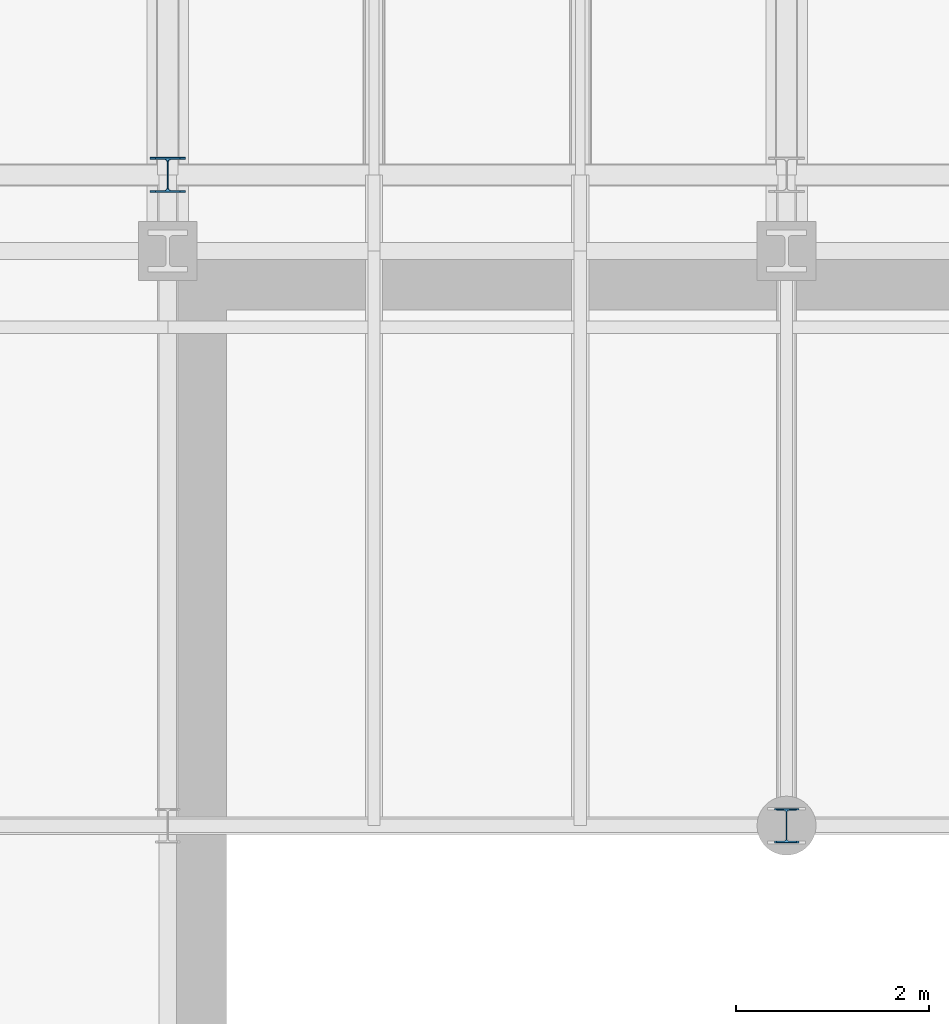
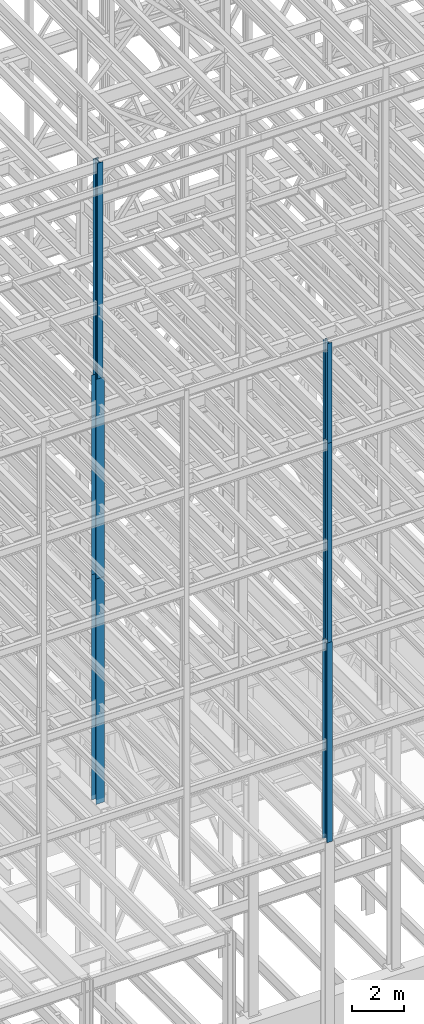
# One storey, part 28 of 150: 6 columns.
"""IFC2X3 building model written with IfcOpenShell, lengths in millimetres."""

from ifc_helpers import new_model, si_unit, frame, origin_with_axes, origin_2d_with_axis, place, context, subcontext, project, spatial, i_section, extrude, material, type_object, element, save


model = new_model("IFC2X3")

# Units and contexts
model_context = context("Model", 3, precision=1e-05, world=origin_with_axes())
body_context = subcontext(model_context, "Body", "Model", "MODEL_VIEW")
ifc_project = project(units=[si_unit("LENGTHUNIT", "METRE", prefix="MILLI"), si_unit("AREAUNIT", "SQUARE_METRE"), si_unit("VOLUMEUNIT", "CUBIC_METRE"), si_unit("MASSUNIT", "GRAM", prefix="KILO"), si_unit("TIMEUNIT", "SECOND"), si_unit("PLANEANGLEUNIT", "RADIAN"), si_unit("SOLIDANGLEUNIT", "STERADIAN"), si_unit("THERMODYNAMICTEMPERATUREUNIT", "DEGREE_CELSIUS"), si_unit("LUMINOUSINTENSITYUNIT", "LUMEN")], contexts=[model_context])

# Site, building, storey
site_placement = place(None, origin_with_axes())
site = spatial("IfcSite", under=ifc_project, at=site_placement, CompositionType="ELEMENT")
building_placement = place(site_placement, origin_with_axes())
building = spatial("IfcBuilding", under=site, at=building_placement, Name="Undefined", CompositionType="ELEMENT")
storey_placement = place(building_placement, origin_with_axes())
storey = spatial("IfcBuildingStorey", under=building, at=storey_placement, Name="Undefined", CompositionType="ELEMENT", Elevation=0.0)

# Columns
ifc_material = material(Name="STEEL/A992")
column_type_1 = type_object("IfcColumnType", Name="W14X43", PredefinedType="NOTDEFINED")
column_1_placement = place(storey_placement, frame((50190.4, 3454.4, 54483.0), z_axis=(0.0, 0.0, 1.0), x_axis=(1.0, 0.0, 0.0)))
element("IfcColumn", 1, at=column_1_placement, inside=storey, type_object=column_type_1, material=ifc_material, Name="COLUMN", ObjectType="W14X43", context=body_context, shape_type="SweptSolid", body=[
    extrude(i_section(OverallWidth=203.2, OverallDepth=346.075, WebThickness=7.9375, FlangeThickness=13.462, FilletRadius=21.4629, at=origin_2d_with_axis()), frame((0.0, 0.0, 4724.39999999999), z_axis=(0.0, 0.0, -1.0), x_axis=(-1.0, 0.0, 0.0)), (0.0, 0.0, 1.0), 4724.4),
])
column_type_2 = type_object("IfcColumnType", Name="W14X53", PredefinedType="NOTDEFINED")
column_2_placement = place(storey_placement, frame((50190.4, 3454.4, 45034.2), z_axis=(0.0, 0.0, 1.0), x_axis=(1.0, 0.0, 0.0)))
element("IfcColumn", 2, at=column_2_placement, inside=storey, type_object=column_type_2, material=ifc_material, Name="COLUMN", ObjectType="W14X53", context=body_context, shape_type="SweptSolid", body=[
    extrude(i_section(OverallWidth=203.2, OverallDepth=352.425, WebThickness=9.5249, FlangeThickness=16.764, FilletRadius=21.336, at=origin_2d_with_axis()), frame((0.0, 0.0, 9448.8), z_axis=(0.0, 0.0, -1.0), x_axis=(-1.0, 0.0, 0.0)), (0.0, 0.0, 1.0), 9448.8),
])
column_type_3 = type_object("IfcColumnType", Name="W14X61", PredefinedType="NOTDEFINED")
column_3_placement = place(storey_placement, frame((43789.6, 10185.4, 55702.2), z_axis=(0.0, 0.0, 1.0), x_axis=(1.0, 0.0, 0.0)))
element("IfcColumn", 3, at=column_3_placement, inside=storey, type_object=column_type_3, material=ifc_material, Name="COLUMN", ObjectType="W14X61", context=body_context, shape_type="SweptSolid", body=[
    extrude(i_section(OverallWidth=254.0, OverallDepth=352.425, WebThickness=9.5249, FlangeThickness=16.383, FilletRadius=21.717, at=origin_2d_with_axis()), frame((0.0, 0.0, 10210.8), z_axis=(0.0, 0.0, -1.0), x_axis=(-1.0, 0.0, 0.0)), (0.0, 0.0, 1.0), 10210.8),
])
column_type_4 = type_object("IfcColumnType", Name="W14X68", PredefinedType="NOTDEFINED")
column_4_placement = place(storey_placement, frame((50190.4, 3454.4, 35585.4), z_axis=(0.0, 0.0, 1.0), x_axis=(1.0, 0.0, 0.0)))
element("IfcColumn", 4, at=column_4_placement, inside=storey, type_object=column_type_4, material=ifc_material, Name="COLUMN", ObjectType="W14X68", context=body_context, shape_type="SweptSolid", body=[
    extrude(i_section(OverallWidth=254.0, OverallDepth=355.6, WebThickness=11.1125, FlangeThickness=18.288, FilletRadius=21.3994, at=origin_2d_with_axis()), frame((0.0, 0.0, 9448.8), z_axis=(0.0, 0.0, -1.0), x_axis=(-1.0, 0.0, 0.0)), (0.0, 0.0, 1.0), 9448.8),
])
column_type_5 = type_object("IfcColumnType", Name="W14X90", PredefinedType="NOTDEFINED")
column_5_placement = place(storey_placement, frame((43789.6, 10185.4, 46253.4), z_axis=(0.0, 0.0, 1.0), x_axis=(1.0, 0.0, 0.0)))
element("IfcColumn", 5, at=column_5_placement, inside=storey, type_object=column_type_5, material=ifc_material, Name="COLUMN", ObjectType="W14X90", context=body_context, shape_type="SweptSolid", body=[
    extrude(i_section(OverallWidth=368.3, OverallDepth=355.6, WebThickness=11.1125, FlangeThickness=18.034, FilletRadius=32.7659, at=origin_2d_with_axis()), frame((0.0, 0.0, 9448.8), z_axis=(0.0, 0.0, -1.0), x_axis=(-1.0, 0.0, 0.0)), (0.0, 0.0, 1.0), 9448.8),
])
column_type_6 = type_object("IfcColumnType", Name="W14X120", PredefinedType="NOTDEFINED")
column_6_placement = place(storey_placement, frame((43789.6, 10185.4, 35585.4), z_axis=(0.0, 0.0, 1.0), x_axis=(1.0, 0.0, 0.0)))
element("IfcColumn", 6, at=column_6_placement, inside=storey, type_object=column_type_6, material=ifc_material, Name="COLUMN", ObjectType="W14X120", context=body_context, shape_type="SweptSolid", body=[
    extrude(i_section(OverallWidth=371.475, OverallDepth=368.3, WebThickness=14.2875, FlangeThickness=23.876, FilletRadius=33.274, at=origin_2d_with_axis()), frame((0.0, 0.0, 10667.9989332), z_axis=(0.0, 0.0, -1.0), x_axis=(-1.0, 0.0, 0.0)), (0.0, 0.0, 1.0), 10667.9989332),
])

save(model, "model.ifc")
